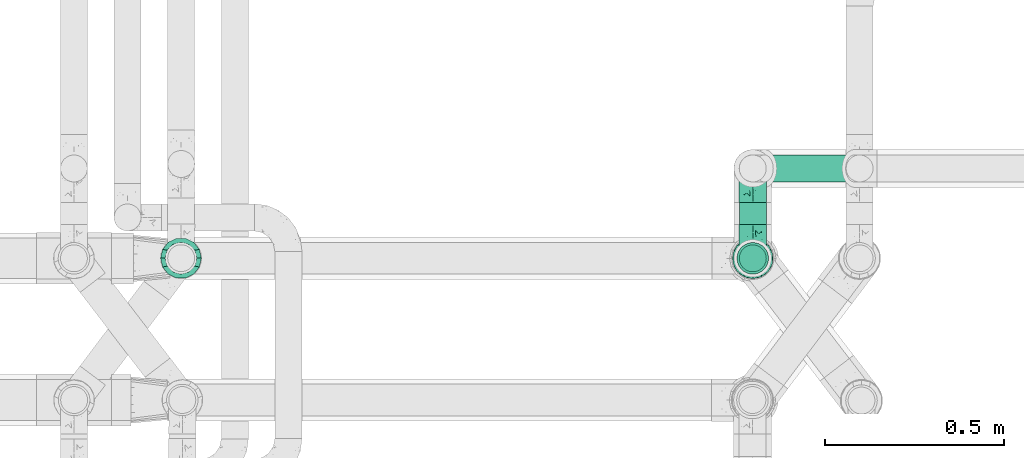
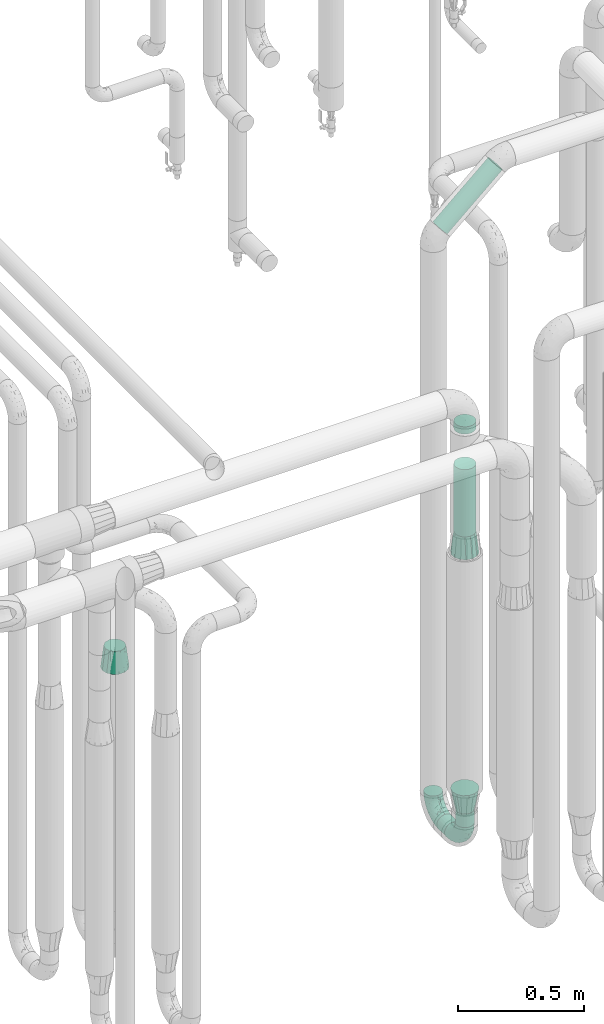
# One storey, part 669 of 827: 5 flow fittings, 5 flow segments.
"""IFC2X3 building model written with IfcOpenShell, lengths in millimetres."""

from ifc_helpers import new_model, entity, si_unit, converted_unit, derived_unit, direction, frame, origin, origin_2d_with_axis, place, context, subcontext, project, spatial, circle, extrude, faceted_brep, source, transform, mapped, material, type_object, type_shapes, element, save


model = new_model("IFC2X3")

# Units and contexts
model_context = context("Model", 3, precision=0.01, world=origin(), true_north=direction((6.12303176911189e-17, 1.0)))
body_context = subcontext(model_context, "Body", "Model", "MODEL_VIEW")
ifc_project = project(units=[si_unit("LENGTHUNIT", "METRE", prefix="MILLI"), si_unit("AREAUNIT", "SQUARE_METRE"), si_unit("VOLUMEUNIT", "CUBIC_METRE"), converted_unit("PLANEANGLEUNIT", "DEGREE", entity("IfcRatioMeasure", 0.0174532925199433), si_unit("PLANEANGLEUNIT", "RADIAN"), dimensions=[0, 0, 0, 0, 0, 0, 0]), si_unit("MASSUNIT", "GRAM", prefix="KILO"), derived_unit("MASSDENSITYUNIT", [(si_unit("MASSUNIT", "GRAM", prefix="KILO"), 1), (si_unit("LENGTHUNIT", "METRE"), -3)]), derived_unit("MOMENTOFINERTIAUNIT", [(si_unit("LENGTHUNIT", "METRE"), 4)]), si_unit("TIMEUNIT", "SECOND"), si_unit("FREQUENCYUNIT", "HERTZ"), si_unit("THERMODYNAMICTEMPERATUREUNIT", "DEGREE_CELSIUS"), derived_unit("THERMALTRANSMITTANCEUNIT", [(si_unit("MASSUNIT", "GRAM", prefix="KILO"), 1), (si_unit("THERMODYNAMICTEMPERATUREUNIT", "KELVIN"), -1), (si_unit("TIMEUNIT", "SECOND"), -3)]), derived_unit("VOLUMETRICFLOWRATEUNIT", [(si_unit("LENGTHUNIT", "METRE"), 3), (si_unit("TIMEUNIT", "SECOND"), -1)]), derived_unit("MASSFLOWRATEUNIT", [(si_unit("MASSUNIT", "GRAM", prefix="KILO"), 1), (si_unit("TIMEUNIT", "SECOND"), -1)]), derived_unit("ROTATIONALFREQUENCYUNIT", [(si_unit("TIMEUNIT", "SECOND"), -1)]), si_unit("ELECTRICCURRENTUNIT", "AMPERE"), si_unit("ELECTRICVOLTAGEUNIT", "VOLT"), si_unit("POWERUNIT", "WATT"), si_unit("FORCEUNIT", "NEWTON", prefix="KILO"), si_unit("ILLUMINANCEUNIT", "LUX"), si_unit("LUMINOUSFLUXUNIT", "LUMEN"), si_unit("LUMINOUSINTENSITYUNIT", "CANDELA"), derived_unit("USERDEFINED", [(si_unit("MASSUNIT", "GRAM", prefix="KILO"), -1), (si_unit("LENGTHUNIT", "METRE"), -2), (si_unit("TIMEUNIT", "SECOND"), 3), (si_unit("LUMINOUSFLUXUNIT", "LUMEN"), 1)]), derived_unit("LINEARVELOCITYUNIT", [(si_unit("LENGTHUNIT", "METRE"), 1), (si_unit("TIMEUNIT", "SECOND"), -1)]), si_unit("PRESSUREUNIT", "PASCAL"), derived_unit("USERDEFINED", [(si_unit("LENGTHUNIT", "METRE"), -2), (si_unit("MASSUNIT", "GRAM", prefix="KILO"), 1), (si_unit("TIMEUNIT", "SECOND"), -2)]), derived_unit("LINEARFORCEUNIT", [(si_unit("MASSUNIT", "GRAM", prefix="KILO"), 1), (si_unit("LENGTHUNIT", "METRE"), 1), (si_unit("TIMEUNIT", "SECOND"), -2), (si_unit("LENGTHUNIT", "METRE"), -1)]), derived_unit("PLANARFORCEUNIT", [(si_unit("MASSUNIT", "GRAM", prefix="KILO"), 1), (si_unit("LENGTHUNIT", "METRE"), 1), (si_unit("TIMEUNIT", "SECOND"), -2), (si_unit("LENGTHUNIT", "METRE"), -2)])], contexts=[model_context])

# Site, building, storey
site_placement = place(None, origin())
site = spatial("IfcSite", under=ifc_project, at=site_placement, CompositionType="ELEMENT")
building_placement = place(site_placement, origin())
building = spatial("IfcBuilding", under=site, at=building_placement, CompositionType="ELEMENT")
storey_placement = place(building_placement, frame((0.0, 0.0, 28200.0)))
storey = spatial("IfcBuildingStorey", under=building, at=storey_placement, Name="08", CompositionType="ELEMENT", Elevation=28200.0)

# Flow segments
pipe_segment_type = type_object("IfcPipeSegmentType", PredefinedType="NOTDEFINED")
flow_segment_1_placement = place(storey_placement, frame((45454.88, 14381.62, 310.65)))
element("IfcFlowSegment", 1, at=flow_segment_1_placement, inside=storey, type_object=pipe_segment_type, context=body_context, shape_type="SweptSolid", body=[
    extrude(circle(Radius=37.75, at=origin_2d_with_axis()), frame((39.35, 0.0, 39.35), z_axis=(0.0, 1.0, 0.0), x_axis=(-1.0, 0.0, 0.0)), (0.0, 0.0, 1.0), 61.4604775254828),
])
flow_segment_2_placement = place(storey_placement, frame((45454.88, 14247.27, 445.0)))
element("IfcFlowSegment", 2, at=flow_segment_2_placement, inside=storey, type_object=pipe_segment_type, context=body_context, shape_type="SweptSolid", body=[
    extrude(circle(Radius=37.75, at=origin_2d_with_axis()), frame((39.35, 39.35, 0.0), z_axis=(0.0, 0.0, 1.0), x_axis=(-1.0, 0.0, 0.0)), (0.0, 0.0, 1.0), 65.0000000000242),
])
flow_segment_3_placement = place(storey_placement, frame((45499.84, 14498.73, 3123.66)))
element("IfcFlowSegment", 3, at=flow_segment_3_placement, inside=storey, type_object=pipe_segment_type, context=body_context, shape_type="SweptSolid", body=[
    extrude(circle(Radius=37.75, at=origin_2d_with_axis()), frame((26.56, 39.35, 29.91), z_axis=(0.750137300458903, 0.0, 0.661282111099513), x_axis=(0.0, -1.0, 0.0)), (0.0, 0.0, 1.0), 336.753261279577),
])
flow_segment_4_placement = place(storey_placement, frame((45448.38, 14240.77, 1854.0)))
element("IfcFlowSegment", 4, at=flow_segment_4_placement, inside=storey, type_object=pipe_segment_type, context=body_context, shape_type="SweptSolid", body=[
    extrude(circle(Radius=44.25, at=origin_2d_with_axis()), frame((45.85, 45.85, 0.0)), (0.0, 0.0, 1.0), 325.000000000008),
])
flow_segment_5_placement = place(storey_placement, frame((45448.38, 14240.77, 2351.0)))
element("IfcFlowSegment", 5, at=flow_segment_5_placement, inside=storey, type_object=pipe_segment_type, context=body_context, shape_type="SweptSolid", body=[
    extrude(circle(Radius=44.25, at=origin_2d_with_axis()), frame((45.85, 45.85, 0.0)), (0.0, 0.0, 1.0), 34.9999999999747),
])

# Flow fittings
ifc_material = material()
pipe_fitting_type_1 = type_object("IfcPipeFittingType", Name="ADSK_1", PredefinedType="NOTDEFINED", material=ifc_material)
shared_shape_1 = source(origin(), body_context, "Body", "Brep", [
    faceted_brep([(-95.0, 19.02, -32.95), (-95.0, 9.85, -36.75), (-95.0, 0.0, -38.05), (-95.0, -9.85, -36.75), (-95.0, -19.03, -32.95), (-95.0, -26.91, -26.91), (-95.0, -32.95, -19.03), (-95.0, -36.75, -9.85), (-95.0, -38.05, 0.0), (-95.0, -36.75, 9.85), (-95.0, -32.95, 19.02), (-95.0, -26.91, 26.91), (-95.0, -19.03, 32.95), (-95.0, -9.85, 36.75), (-95.0, 0.0, 38.05), (-95.0, 9.85, 36.75), (-95.0, 19.02, 32.95), (-95.0, 26.91, 26.91), (-95.0, 32.95, 19.02), (-95.0, 36.75, 9.85), (-95.0, 38.05, 0.0), (-95.0, 36.75, -9.85), (-95.0, 32.95, -19.03), (-95.0, 26.91, -26.91), (0.0, 95.0, -38.05), (-9.85, 95.0, -36.75), (-19.02, 95.0, -32.95), (-26.91, 95.0, -26.91), (-32.95, 95.0, -19.03), (-36.75, 95.0, -9.85), (-38.05, 95.0, 0.0), (-36.75, 95.0, 9.85), (-32.95, 95.0, 19.02), (-26.91, 95.0, 26.91), (-19.02, 95.0, 32.95), (-9.85, 95.0, 36.75), (0.0, 95.0, 38.05), (9.85, 95.0, 36.75), (19.03, 95.0, 32.95), (26.91, 95.0, 26.91), (32.95, 95.0, 19.02), (36.75, 95.0, 9.85), (38.05, 95.0, 0.0), (36.75, 95.0, -9.85), (32.95, 95.0, -19.03), (26.91, 95.0, -26.91), (19.03, 95.0, -32.95), (9.85, 95.0, -36.75), (-7.99, -4.96, 6.3), (-0.92, 0.92, 0.0), (4.62, 8.1, 8.01), (-76.19, -35.57, 0.0), (-64.32, -32.32, 12.43), (20.51, 62.45, 28.68), (-60.56, -33.52, 0.0), (-70.4, -13.47, 34.42), (-39.61, -5.88, 32.32), (-49.6, 2.07, 37.1), (-70.34, -28.81, 21.71), (14.64, 40.81, 26.5), (5.88, 39.61, 32.32), (3.59, 20.77, 25.31), (-40.45, 68.06, 16.75), (-62.45, -20.51, 28.68), (-44.52, -26.87, 0.0), (-28.47, -20.22, 0.0), (-26.43, -17.83, 8.75), (-76.1, 39.63, 10.76), (-72.74, 37.58, 18.19), (-60.35, 46.18, 14.61), (-13.4, 13.4, 32.12), (-20.77, -3.59, 25.31), (-14.66, 81.47, 35.56), (-6.22, 71.26, 37.92), (-57.5, 42.48, 22.79), (-15.0, 34.74, 37.7), (-27.1, 12.08, 36.05), (-9.2, 28.81, 35.63), (-79.98, 23.7, 30.95), (-73.68, -4.3, 37.48), (-30.74, 21.67, 37.97), (-62.36, 47.59, 6.79), (-72.71, 32.83, 24.69), (-67.42, 7.02, 37.95), (-32.13, 75.27, 24.51), (-43.46, 51.47, 26.26), (-24.98, 73.15, 31.29), (20.59, 41.28, 19.85), (7.79, 16.09, 15.86), (-73.21, 42.39, 0.0), (-54.73, 54.73, 0.0), (-73.44, 15.79, 35.79), (-5.94, 4.32, 20.43), (28.81, 70.34, 21.71), (32.32, 64.32, 12.43), (-53.59, 26.2, 35.09), (-52.02, 19.31, 37.21), (21.38, 33.53, 10.34), (26.87, 44.52, 0.0), (-48.28, 12.14, 38.05), (4.3, 73.68, 37.48), (-44.08, -25.52, 12.79), (-41.28, -20.59, 19.85), (35.57, 76.19, 0.0), (-47.26, 54.3, 20.18), (-47.4, 61.99, 8.58), (-42.39, 73.21, 0.0), (-39.67, 78.86, 7.21), (-45.69, 36.84, 33.11), (-32.83, 50.13, 33.35), (13.47, 70.4, 34.42), (-18.25, 63.73, 36.07), (-40.63, -13.75, 27.22), (-16.63, 46.37, 37.95), (-53.47, 38.79, 28.59), (-26.07, 48.54, 36.15), (-34.51, 34.51, 36.86), (-2.07, 49.6, 37.1), (-22.79, -10.49, 19.23), (-61.73, 28.67, 31.87), (9.65, 14.7, 0.0), (20.22, 28.47, 0.0), (33.52, 60.56, 0.0), (-11.42, -5.44, 13.25), (-14.7, -9.65, 0.0), (-81.47, 14.66, -35.56), (-62.45, -20.51, -28.68), (-71.26, 6.22, -37.92), (-75.27, 32.13, -24.51), (-73.15, 24.98, -31.29), (13.47, 70.4, -34.42), (5.88, 39.61, -32.32), (-2.07, 49.6, -37.1), (-78.86, 39.67, -7.21), (-70.4, -13.47, -34.42), (-39.61, -5.88, -32.32), (-61.99, 47.4, -8.58), (32.32, 64.32, -12.43), (28.81, 70.34, -21.71), (-63.73, 18.25, -36.07), (-50.13, 32.83, -33.35), (4.3, 73.68, -37.48), (-7.02, 67.42, -37.95), (-39.63, 76.1, -10.76), (-46.18, 60.35, -14.61), (-47.59, 62.36, -6.79), (-64.32, -32.32, -12.43), (-26.2, 53.59, -35.09), (-15.79, 73.44, -35.79), (-19.31, 52.02, -37.21), (-37.58, 72.74, -18.19), (-70.34, -28.81, -21.71), (-42.48, 57.5, -22.79), (-38.79, 53.47, -28.59), (-51.47, 43.46, -26.26), (-32.83, 72.71, -24.69), (-46.37, 16.63, -37.95), (-73.68, -4.3, -37.48), (-41.28, -20.59, -19.85), (-44.08, -25.52, -12.79), (13.75, 40.63, -27.22), (20.51, 62.45, -28.68), (-68.06, 40.45, -16.75), (-54.3, 47.26, -20.18), (-12.14, 48.28, -38.05), (-21.67, 30.74, -37.97), (-36.84, 45.69, -33.11), (-11.42, -5.44, -13.25), (7.79, 16.09, -15.86), (4.62, 8.1, -8.01), (-23.7, 79.98, -30.95), (-26.43, -17.83, -8.75), (-7.99, -4.96, -6.3), (-40.81, -14.64, -26.5), (-20.77, -3.59, -25.31), (-34.74, 15.0, -37.7), (-12.08, 27.1, -36.05), (-28.81, 9.2, -35.63), (-22.79, -10.49, -19.23), (21.38, 33.53, -10.34), (20.59, 41.28, -19.85), (-48.54, 26.07, -36.15), (-49.6, 2.07, -37.1), (-13.4, 13.4, -32.12), (3.59, 20.77, -25.31), (-28.67, 61.73, -31.87), (-34.51, 34.51, -36.86), (-5.94, 4.32, -20.43)], [[[0, 1, 2, 3, 4, 5, 6, 7, 8, 9, 10, 11, 12, 13, 14, 15, 16, 17, 18, 19, 20, 21, 22, 23]], [[24, 25, 26, 27, 28, 29, 30, 31, 32, 33, 34, 35, 36, 37, 38, 39, 40, 41, 42, 43, 44, 45, 46, 47]], [[48, 49, 50]], [[51, 52, 9]], [[53, 39, 38]], [[9, 52, 10]], [[54, 52, 51]], [[55, 56, 57]], [[11, 10, 58]], [[59, 60, 61]], [[32, 31, 62]], [[63, 12, 11]], [[63, 55, 12]], [[64, 65, 66]], [[67, 68, 69]], [[70, 56, 71]], [[35, 72, 73]], [[69, 68, 74]], [[75, 76, 77]], [[16, 78, 17]], [[13, 79, 14]], [[76, 75, 80]], [[67, 69, 81]], [[18, 17, 82]], [[14, 79, 83]], [[20, 19, 67]], [[84, 85, 86]], [[87, 61, 88]], [[89, 81, 90]], [[18, 82, 68]], [[15, 91, 16]], [[14, 83, 15]], [[71, 92, 61]], [[17, 78, 82]], [[93, 87, 94]], [[95, 91, 96]], [[97, 98, 94]], [[86, 72, 34]], [[96, 99, 80]], [[37, 36, 100]], [[40, 39, 93]], [[40, 94, 41]], [[64, 66, 101]], [[93, 94, 40]], [[58, 102, 63]], [[94, 103, 41]], [[94, 87, 97]], [[104, 69, 74]], [[34, 33, 86]], [[105, 69, 104]], [[52, 58, 10]], [[106, 107, 30]], [[108, 109, 85]], [[105, 106, 90]], [[53, 110, 60]], [[86, 111, 72]], [[86, 109, 111]], [[33, 84, 86]], [[12, 55, 13]], [[112, 56, 63]], [[110, 38, 37]], [[34, 72, 35]], [[36, 35, 73]], [[111, 113, 73]], [[105, 107, 106]], [[110, 53, 38]], [[74, 114, 85]], [[91, 15, 83]], [[105, 90, 81]], [[107, 62, 31]], [[33, 32, 84]], [[115, 109, 116]], [[111, 115, 113]], [[100, 73, 117]], [[56, 55, 63]], [[79, 55, 57]], [[102, 118, 112]], [[56, 70, 76]], [[100, 110, 37]], [[117, 77, 60]], [[117, 60, 110]], [[60, 70, 61]], [[58, 52, 101]], [[63, 11, 58]], [[39, 53, 93]], [[87, 93, 53]], [[96, 91, 83]], [[78, 91, 119]], [[32, 62, 84]], [[84, 62, 104]], [[86, 85, 109]], [[85, 114, 108]], [[80, 113, 116]], [[117, 73, 113]], [[80, 116, 96]], [[80, 57, 76]], [[71, 112, 118]], [[61, 87, 59]], [[62, 107, 105]], [[97, 120, 121]], [[70, 71, 61]], [[71, 118, 92]], [[73, 100, 36]], [[110, 100, 117]], [[55, 79, 13]], [[83, 79, 57]], [[96, 83, 99]], [[116, 108, 95]], [[50, 97, 88]], [[97, 87, 88]], [[50, 49, 120]], [[122, 94, 98]], [[89, 20, 67]], [[105, 81, 69]], [[89, 67, 81]], [[68, 19, 18]], [[68, 67, 19]], [[74, 68, 82]], [[114, 82, 119]], [[74, 85, 104]], [[82, 114, 74]], [[114, 119, 108]], [[95, 108, 119]], [[116, 109, 108]], [[123, 48, 50]], [[97, 50, 120]], [[123, 50, 88]], [[91, 95, 119]], [[116, 95, 96]], [[84, 104, 85]], [[104, 62, 105]], [[83, 57, 99]], [[57, 80, 99]], [[66, 48, 123]], [[66, 124, 48]], [[118, 66, 123]], [[124, 66, 65]], [[66, 118, 101]], [[54, 64, 52]], [[124, 49, 48]], [[30, 107, 31]], [[91, 78, 16]], [[82, 78, 119]], [[56, 76, 57]], [[77, 76, 70]], [[60, 77, 70]], [[77, 117, 75]], [[117, 113, 75]], [[113, 80, 75]], [[9, 8, 51]], [[103, 94, 122]], [[103, 42, 41]], [[73, 72, 111]], [[113, 115, 116]], [[111, 109, 115]], [[102, 112, 63]], [[71, 56, 112]], [[118, 102, 101]], [[92, 123, 88]], [[123, 92, 118]], [[61, 92, 88]], [[87, 53, 59]], [[60, 59, 53]], [[97, 121, 98]], [[58, 101, 102]], [[64, 101, 52]], [[125, 1, 0]], [[126, 5, 4]], [[2, 1, 127]], [[1, 125, 127]], [[128, 129, 23]], [[130, 131, 132]], [[89, 133, 20]], [[126, 134, 135]], [[136, 89, 90]], [[137, 138, 44]], [[139, 129, 140]], [[24, 141, 142]], [[143, 144, 145]], [[125, 129, 139]], [[6, 146, 7]], [[147, 148, 149]], [[146, 51, 7]], [[143, 150, 144]], [[146, 6, 151]], [[152, 153, 154]], [[126, 4, 134]], [[0, 23, 129]], [[28, 155, 150]], [[43, 42, 103]], [[54, 146, 64]], [[139, 156, 127]], [[157, 3, 2]], [[151, 158, 159]], [[160, 131, 161]], [[22, 21, 162]], [[136, 144, 163]], [[149, 164, 165]], [[24, 142, 25]], [[166, 140, 154]], [[154, 129, 128]], [[143, 30, 29]], [[167, 168, 169]], [[155, 28, 27]], [[26, 170, 27]], [[171, 167, 172]], [[26, 25, 148]], [[27, 170, 155]], [[173, 135, 174]], [[144, 150, 152]], [[175, 176, 177]], [[24, 47, 141]], [[45, 161, 46]], [[148, 25, 142]], [[176, 175, 165]], [[64, 159, 171]], [[138, 45, 44]], [[130, 46, 161]], [[137, 44, 43]], [[178, 159, 158]], [[137, 103, 122]], [[163, 144, 152]], [[136, 133, 89]], [[103, 137, 43]], [[6, 5, 151]], [[178, 158, 173]], [[134, 4, 3]], [[178, 173, 174]], [[137, 98, 179]], [[145, 90, 106]], [[138, 180, 161]], [[46, 130, 47]], [[136, 90, 145]], [[133, 162, 21]], [[23, 22, 128]], [[139, 140, 181]], [[139, 181, 156]], [[157, 127, 182]], [[157, 134, 3]], [[182, 177, 135]], [[182, 135, 134]], [[135, 183, 174]], [[131, 130, 161]], [[141, 130, 132]], [[160, 180, 184]], [[131, 183, 176]], [[5, 126, 151]], [[158, 151, 126]], [[180, 138, 137]], [[161, 45, 138]], [[149, 148, 142]], [[170, 148, 185]], [[22, 162, 128]], [[128, 162, 163]], [[129, 154, 140]], [[154, 153, 166]], [[165, 156, 186]], [[182, 127, 156]], [[165, 186, 149]], [[165, 132, 176]], [[131, 184, 183]], [[187, 167, 178]], [[184, 168, 187]], [[167, 169, 172]], [[184, 180, 168]], [[174, 183, 184]], [[127, 157, 2]], [[134, 157, 182]], [[130, 141, 47]], [[142, 141, 132]], [[149, 142, 164]], [[186, 166, 147]], [[180, 179, 168]], [[169, 179, 120]], [[137, 179, 180]], [[179, 121, 120]], [[106, 30, 143]], [[136, 145, 144]], [[106, 143, 145]], [[150, 29, 28]], [[150, 143, 29]], [[152, 150, 155]], [[153, 155, 185]], [[152, 154, 163]], [[155, 153, 152]], [[153, 185, 166]], [[147, 166, 185]], [[186, 140, 166]], [[169, 120, 49]], [[169, 49, 172]], [[179, 169, 168]], [[148, 147, 185]], [[186, 147, 149]], [[128, 163, 154]], [[163, 162, 136]], [[142, 132, 164]], [[132, 165, 164]], [[171, 124, 65]], [[124, 171, 172]], [[64, 146, 159]], [[171, 159, 178]], [[171, 65, 64]], [[172, 49, 124]], [[162, 133, 136]], [[20, 133, 21]], [[148, 170, 26]], [[155, 170, 185]], [[131, 176, 132]], [[177, 176, 183]], [[135, 177, 183]], [[177, 182, 175]], [[182, 156, 175]], [[156, 165, 175]], [[51, 146, 54]], [[51, 8, 7]], [[129, 125, 0]], [[127, 125, 139]], [[140, 186, 181]], [[156, 181, 186]], [[158, 126, 173]], [[135, 173, 126]], [[187, 178, 174]], [[171, 178, 167]], [[184, 187, 174]], [[167, 187, 168]], [[180, 160, 161]], [[184, 131, 160]], [[98, 137, 122]], [[98, 121, 179]], [[151, 159, 146]]]),
])
type_shapes(pipe_fitting_type_1, [shared_shape_1])
for number, where, z_axis, x_axis, name in (
    (6, (45494.22, 14538.08, 350.0), (-1.0, 0.0, 0.0), (0.0, 0.0, -1.0), "ADSK_1"),
    (7, (45494.22, 14286.62, 350.0), (-1.0, 0.0, 0.0), (0.0, -1.0, 0.0), "ADSK_1"),
):
    element("IfcFlowFitting", number, at=place(storey_placement, frame(where, z_axis=z_axis, x_axis=x_axis)), inside=storey, type_object=pipe_fitting_type_1, material=ifc_material, Name=name, ObjectType="ADSK_1", context=body_context, shape_type="MappedRepresentation", body=[
        mapped(shared_shape_1, transform((0.0, 0.0, 0.0), scale=1.0)),
    ])
pipe_fitting_type_2 = type_object("IfcPipeFittingType", Name="ADSK_1", PredefinedType="NOTDEFINED", material=ifc_material)
shared_shape_2 = source(origin(), body_context, "Body", "Brep", [
    faceted_brep([(102.0, -30.36, 30.36), (102.0, -38.49, 22.23), (102.0, -41.47, 11.11), (102.0, -44.45, 0.0), (102.0, -41.47, -11.11), (102.0, -38.49, -22.22), (102.0, -30.36, -30.36), (102.0, -22.23, -38.49), (102.0, -11.11, -41.47), (102.0, 0.0, -44.45), (102.0, 11.11, -41.47), (102.0, 22.22, -38.49), (102.0, 30.36, -30.36), (102.0, 38.49, -22.22), (102.0, 41.47, -11.11), (102.0, 44.45, 0.0), (102.0, 41.47, 11.11), (102.0, 38.49, 22.23), (102.0, 30.36, 30.36), (102.0, 22.22, 38.49), (102.0, 11.11, 41.47), (102.0, 0.0, 44.45), (102.0, -11.11, 41.47), (102.0, -22.23, 38.49), (0.0, 24.17, 50.2), (0.0, 35.63, 44.68), (0.0, 43.56, 34.74), (0.0, 51.49, 24.8), (0.0, 54.32, 12.4), (0.0, 57.15, 0.0), (0.0, 54.32, -12.4), (0.0, 51.49, -24.8), (0.0, 43.56, -34.74), (0.0, 35.63, -44.68), (0.0, 24.17, -50.2), (0.0, 12.72, -55.72), (0.0, 0.0, -55.72), (0.0, -12.72, -55.72), (0.0, -24.17, -50.2), (0.0, -35.63, -44.68), (0.0, -43.56, -34.74), (0.0, -51.49, -24.8), (0.0, -54.32, -12.4), (0.0, -57.15, 0.0), (0.0, -54.32, 12.4), (0.0, -51.49, 24.8), (0.0, -43.56, 34.74), (0.0, -35.63, 44.68), (0.0, -24.17, 50.2), (0.0, -12.72, 55.72), (0.0, 0.0, 55.72), (0.0, 12.72, 55.72)], [[[0, 1, 2, 3, 4, 5, 6, 7, 8, 9, 10, 11, 12, 13, 14, 15, 16, 17, 18, 19, 20, 21, 22, 23]], [[24, 25, 26, 27, 28, 29, 30, 31, 32, 33, 34, 35, 36, 37, 38, 39, 40, 41, 42, 43, 44, 45, 46, 47, 48, 49, 50, 51]], [[14, 31, 30]], [[42, 3, 43]], [[32, 31, 13]], [[13, 31, 14]], [[34, 10, 35]], [[3, 42, 4]], [[12, 11, 33]], [[9, 37, 36, 35]], [[7, 39, 38]], [[39, 7, 6]], [[38, 8, 7]], [[34, 33, 11]], [[10, 9, 35]], [[40, 5, 41]], [[12, 33, 32]], [[15, 30, 29]], [[38, 37, 8]], [[15, 14, 30]], [[41, 5, 4]], [[5, 40, 6]], [[13, 12, 32]], [[10, 34, 11]], [[37, 9, 8]], [[40, 39, 6]], [[42, 41, 4]], [[2, 45, 44]], [[28, 15, 29]], [[46, 45, 1]], [[1, 45, 2]], [[48, 22, 49]], [[15, 28, 16]], [[0, 23, 47]], [[21, 51, 50, 49]], [[19, 25, 24]], [[25, 19, 18]], [[24, 20, 19]], [[48, 47, 23]], [[22, 21, 49]], [[26, 17, 27]], [[0, 47, 46]], [[3, 44, 43]], [[24, 51, 20]], [[3, 2, 44]], [[27, 17, 16]], [[17, 26, 18]], [[1, 0, 46]], [[22, 48, 23]], [[51, 21, 20]], [[26, 25, 18]], [[28, 27, 16]]]),
])
type_shapes(pipe_fitting_type_2, [shared_shape_2])
for number, where, z_axis, x_axis, name in (
    (8, (45494.22, 14286.62, 1752.0), (1.0, 0.0, 0.0), (0.0, 0.0, 1.0), "ADSK_1"),
    (9, (43894.55, 14286.99, 1758.0), (0.0, 1.0, 0.0), (-0.000462463929099557, 0.0, 0.999999893063551), "ADSK_1"),
):
    element("IfcFlowFitting", number, at=place(storey_placement, frame(where, z_axis=z_axis, x_axis=x_axis)), inside=storey, type_object=pipe_fitting_type_2, material=ifc_material, Name=name, ObjectType="ADSK_1", context=body_context, shape_type="MappedRepresentation", body=[
        mapped(shared_shape_2, transform((0.0, 0.0, 0.0), scale=1.0)),
    ])
pipe_fitting_type_3 = type_object("IfcPipeFittingType", Name="ADSK_1", PredefinedType="NOTDEFINED", material=ifc_material)
shared_shape_3 = source(origin(), body_context, "Body", "Brep", [
    faceted_brep([(102.0, -57.15, 0.0), (102.0, -54.32, -12.4), (102.0, -51.49, -24.8), (102.0, -43.56, -34.74), (102.0, -35.63, -44.68), (102.0, -24.17, -50.2), (102.0, -12.72, -55.72), (102.0, 0.0, -55.72), (102.0, 12.72, -55.72), (102.0, 24.17, -50.2), (102.0, 35.63, -44.68), (102.0, 43.56, -34.74), (102.0, 51.49, -24.8), (102.0, 54.32, -12.4), (102.0, 57.15, 0.0), (102.0, 54.32, 12.4), (102.0, 51.49, 24.8), (102.0, 43.56, 34.74), (102.0, 35.63, 44.68), (102.0, 24.17, 50.2), (102.0, 12.72, 55.72), (102.0, 0.0, 55.72), (102.0, -12.72, 55.72), (102.0, -24.17, 50.2), (102.0, -35.63, 44.68), (102.0, -43.56, 34.74), (102.0, -51.49, 24.8), (102.0, -54.32, 12.4), (0.0, 38.05, 0.0), (0.0, 35.5, -9.51), (0.0, 32.95, -19.02), (0.0, 25.99, -25.99), (0.0, 19.02, -32.95), (0.0, 9.51, -35.5), (0.0, 0.0, -38.05), (0.0, -9.51, -35.5), (0.0, -19.02, -32.95), (0.0, -25.99, -25.99), (0.0, -32.95, -19.02), (0.0, -35.5, -9.51), (0.0, -38.05, 0.0), (0.0, -35.5, 9.51), (0.0, -32.95, 19.03), (0.0, -25.99, 25.99), (0.0, -19.03, 32.95), (0.0, -9.51, 35.5), (0.0, 0.0, 38.05), (0.0, 9.51, 35.5), (0.0, 19.03, 32.95), (0.0, 25.99, 25.99), (0.0, 32.95, 19.03), (0.0, 35.5, 9.51)], [[[0, 1, 2, 3, 4, 5, 6, 7, 8, 9, 10, 11, 12, 13, 14, 15, 16, 17, 18, 19, 20, 21, 22, 23, 24, 25, 26, 27]], [[28, 29, 30, 31, 32, 33, 34, 35, 36, 37, 38, 39, 40, 41, 42, 43, 44, 45, 46, 47, 48, 49, 50, 51]], [[38, 2, 39]], [[11, 10, 31]], [[8, 34, 33]], [[3, 2, 38]], [[40, 39, 1]], [[28, 13, 29]], [[40, 1, 0]], [[32, 10, 9]], [[34, 8, 7, 6]], [[37, 36, 4]], [[39, 2, 1]], [[33, 32, 9]], [[38, 37, 3]], [[37, 4, 3]], [[5, 4, 36]], [[13, 28, 14]], [[10, 32, 31]], [[8, 33, 9]], [[35, 5, 36]], [[30, 11, 31]], [[29, 12, 30]], [[5, 35, 6]], [[35, 34, 6]], [[11, 30, 12]], [[13, 12, 29]], [[50, 16, 51]], [[25, 24, 43]], [[22, 46, 45]], [[17, 16, 50]], [[28, 51, 15]], [[40, 27, 41]], [[28, 15, 14]], [[44, 24, 23]], [[46, 22, 21, 20]], [[49, 48, 18]], [[51, 16, 15]], [[45, 44, 23]], [[50, 49, 17]], [[49, 18, 17]], [[19, 18, 48]], [[27, 40, 0]], [[24, 44, 43]], [[22, 45, 23]], [[47, 19, 48]], [[42, 25, 43]], [[41, 26, 42]], [[19, 47, 20]], [[47, 46, 20]], [[25, 42, 26]], [[27, 26, 41]]]),
])
type_shapes(pipe_fitting_type_3, [shared_shape_3])
flow_fitting_placement = place(storey_placement, frame((45494.22, 14286.62, 510.0), z_axis=(0.0, 1.0, 0.0), x_axis=(0.0, 0.0, 1.0)))
element("IfcFlowFitting", 10, at=flow_fitting_placement, inside=storey, type_object=pipe_fitting_type_3, material=ifc_material, Name="ADSK_1", ObjectType="ADSK_1", context=body_context, shape_type="MappedRepresentation", body=[
    mapped(shared_shape_3, transform((0.0, 0.0, 0.0), scale=1.0)),
])

save(model, "model.ifc")
